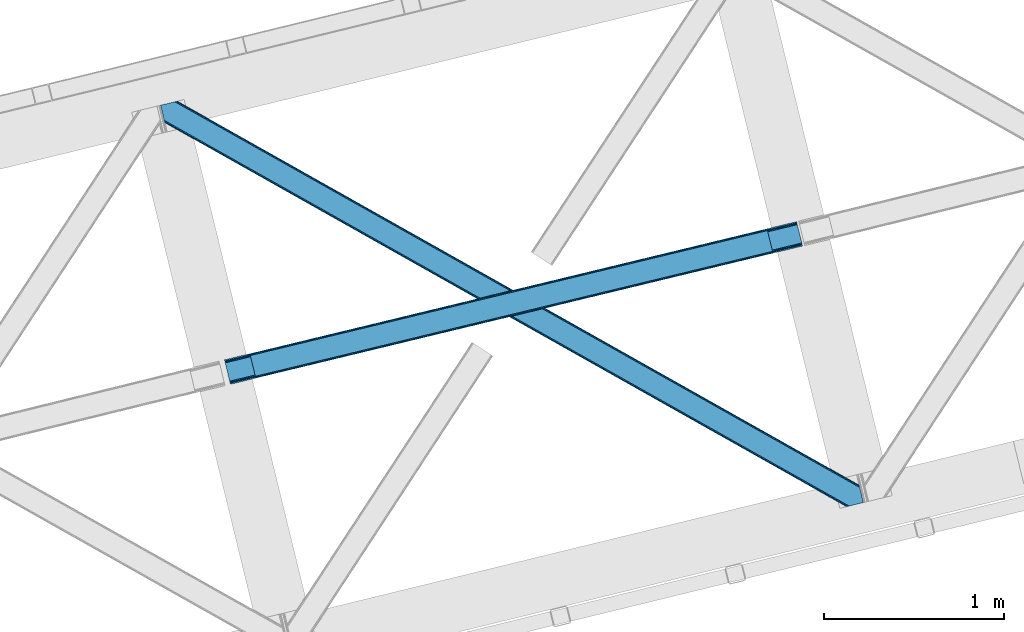
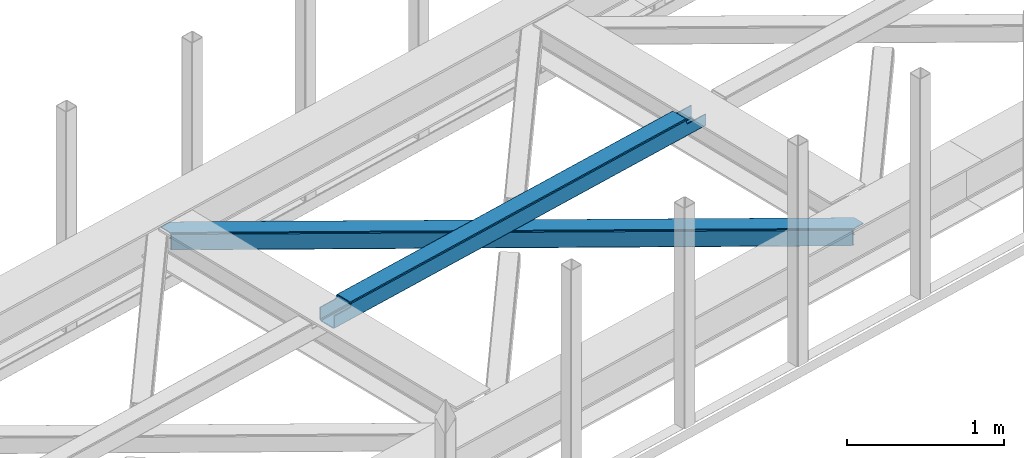
# One storey, part 28 of 66: 1 beam, 1 member.
"""IFC4 building model written with IfcOpenShell, lengths in millimetres."""

from ifc_helpers import new_model, entity, si_unit, converted_unit, derived_unit, direction, frame, origin, place, context, subcontext, project, spatial, triangles, type_object, element, save


model = new_model("IFC4")

# Units and contexts
model_context = context("Model", 3, precision=0.01, world=origin(), true_north=direction((6.12303176911189e-17, 1.0)))
plan_context = context("Plan", 3, precision=0.01, world=origin(), true_north=direction((6.12303176911189e-17, 1.0)))
body_context = subcontext(model_context, "Body", "Model", "MODEL_VIEW")
ifc_project = project(units=[si_unit("LENGTHUNIT", "METRE", prefix="MILLI"), si_unit("AREAUNIT", "SQUARE_METRE"), si_unit("VOLUMEUNIT", "CUBIC_METRE"), converted_unit("PLANEANGLEUNIT", "DEGREE", entity("IfcRatioMeasure", 0.0174532925199433), si_unit("PLANEANGLEUNIT", "RADIAN"), dimensions=[0, 0, 0, 0, 0, 0, 0]), si_unit("MASSUNIT", "GRAM", prefix="KILO"), derived_unit("MASSDENSITYUNIT", [(si_unit("MASSUNIT", "GRAM", prefix="KILO"), 1), (si_unit("LENGTHUNIT", "METRE"), -3)]), derived_unit("MOMENTOFINERTIAUNIT", [(si_unit("LENGTHUNIT", "METRE"), 4)]), si_unit("TIMEUNIT", "SECOND"), si_unit("FREQUENCYUNIT", "HERTZ"), si_unit("THERMODYNAMICTEMPERATUREUNIT", "DEGREE_CELSIUS"), derived_unit("THERMALTRANSMITTANCEUNIT", [(si_unit("MASSUNIT", "GRAM", prefix="KILO"), 1), (si_unit("THERMODYNAMICTEMPERATUREUNIT", "KELVIN"), -1), (si_unit("TIMEUNIT", "SECOND"), -3)]), derived_unit("VOLUMETRICFLOWRATEUNIT", [(si_unit("LENGTHUNIT", "METRE"), 3), (si_unit("TIMEUNIT", "SECOND"), -1)]), derived_unit("MASSFLOWRATEUNIT", [(si_unit("MASSUNIT", "GRAM", prefix="KILO"), 1), (si_unit("TIMEUNIT", "SECOND"), -1)]), derived_unit("ROTATIONALFREQUENCYUNIT", [(si_unit("TIMEUNIT", "SECOND"), -1)]), si_unit("ELECTRICCURRENTUNIT", "AMPERE"), si_unit("ELECTRICVOLTAGEUNIT", "VOLT"), si_unit("POWERUNIT", "WATT"), si_unit("FORCEUNIT", "NEWTON", prefix="KILO"), si_unit("ILLUMINANCEUNIT", "LUX"), si_unit("LUMINOUSFLUXUNIT", "LUMEN"), si_unit("LUMINOUSINTENSITYUNIT", "CANDELA"), derived_unit("USERDEFINED", [(si_unit("MASSUNIT", "GRAM", prefix="KILO"), -1), (si_unit("LENGTHUNIT", "METRE"), -2), (si_unit("TIMEUNIT", "SECOND"), 3), (si_unit("LUMINOUSFLUXUNIT", "LUMEN"), 1)]), derived_unit("LINEARVELOCITYUNIT", [(si_unit("LENGTHUNIT", "METRE"), 1), (si_unit("TIMEUNIT", "SECOND"), -1)]), si_unit("PRESSUREUNIT", "PASCAL"), derived_unit("USERDEFINED", [(si_unit("LENGTHUNIT", "METRE"), -2), (si_unit("MASSUNIT", "GRAM", prefix="KILO"), 1), (si_unit("TIMEUNIT", "SECOND"), -2)]), derived_unit("LINEARFORCEUNIT", [(si_unit("MASSUNIT", "GRAM", prefix="KILO"), 1), (si_unit("LENGTHUNIT", "METRE"), 1), (si_unit("TIMEUNIT", "SECOND"), -2), (si_unit("LENGTHUNIT", "METRE"), -1)]), derived_unit("PLANARFORCEUNIT", [(si_unit("MASSUNIT", "GRAM", prefix="KILO"), 1), (si_unit("LENGTHUNIT", "METRE"), 1), (si_unit("TIMEUNIT", "SECOND"), -2), (si_unit("LENGTHUNIT", "METRE"), -2)])], contexts=[model_context, plan_context])

# Site, building, storey
site_placement = place(None, origin())
site = spatial("IfcSite", under=ifc_project, at=site_placement, CompositionType="ELEMENT")
building_placement = place(site_placement, origin())
building = spatial("IfcBuilding", under=site, at=building_placement, CompositionType="ELEMENT")
storey_placement = place(building_placement, frame((0.0, 0.0, 19800.0)))
storey = spatial("IfcBuildingStorey", under=building, at=storey_placement, Name="06", CompositionType="ELEMENT", Elevation=19800.0)

# Beam
beam_type = type_object("IfcBeamType", PredefinedType="BEAM")
beam_placement = place(storey_placement, frame((-45771.85, 7982.52, 3967.03)))
element("IfcBeam", 1, at=beam_placement, inside=storey, type_object=beam_type, ObjectType="Steel Beam", PredefinedType="BEAM", context=body_context, shape_type="Tessellation", body=[
    triangles([(3181.73602294922, 886.704597473145, 0.969708251952397), (3206.60427246094, 784.691638183594, 0.969708251952397), (29.012182617189, 17.0018692016602, 0.0), (4.14393310547166, 119.015409851074, 0.0), (3180.15007324219, 893.211177062989, 2.30218505859375), (2.5579833984375, 125.521989440918, 1.33247680664135), (3178.80596923828, 898.727119445801, 6.09497680663844), (1.21387939453416, 131.037350463867, 5.12526855468604), (3177.90834960938, 902.412940979004, 11.7736999511726), (0.316259765626455, 134.72317199707, 10.8016662597656), (3177.59208984375, 903.707048034668, 18.4709655761726), (0.0, 136.017279052734, 17.4989318847656), (3210.43194580078, 768.983876037597, 11.7736999511726), (3210.74820556641, 767.689187622071, 18.4709655761726), (33.1561157226606, 0.0, 17.4989318847656), (32.8398559570342, 1.29410705566443, 10.8016662597656), (3209.53432617188, 772.669116210938, 6.09497680663844), (31.9422363281265, 4.97992858886755, 5.12526855468604), (3208.19022216797, 778.18505859375, 2.30218505859375), (30.5981323242231, 10.4952896118166, 1.33247680664135), (3179.5640625, 895.611611938477, 18.7732727050789), (3177.59208984375, 903.707048034668, 100.470611572266), (3179.24780273438, 896.906300354003, 25.4705383300789), (3179.24780273438, 896.906300354003, 100.470611572266), (3180.46168212891, 891.926371765137, 13.0945495605447), (3181.81043701172, 886.410429382324, 9.3017578125), (3183.39638671876, 879.903849792481, 7.96928100585865), (3207.87396240234, 779.470445251465, 13.0945495605447), (3208.77623291016, 775.784623718262, 18.7732727050789), (3209.08784179688, 774.490516662598, 25.4705383300789), (3210.74820556641, 767.689187622071, 100.470611572266), (3209.08784179688, 774.490516662598, 100.470611572266), (3206.52985839844, 784.986387634277, 9.3017578125), (3204.94390869141, 791.492385864258, 7.96928100585865), (27.3518188476592, 23.8026168823244, 6.99957275390625), (5.79964599609957, 112.214662170411, 6.99957275390625), (1.97197265625437, 127.922424316406, 17.8035644531228), (1.65571289062791, 129.216531372071, 24.4985046386719), (2.86959228516207, 124.236602783203, 12.1248413085923), (4.21369628906541, 118.72066040039, 8.3320495605476), (28.9377685546933, 17.2966186523436, 8.3320495605476), (30.2818725585967, 11.7806762695309, 12.1248413085923), (31.1794921875044, 8.09485473632776, 17.8035644531228), (31.4957519531308, 6.80074768066424, 24.4985046386719), (3015.94614257813, 857.452894592285, 100.470611572266), (3014.29042968751, 864.254223632812, 100.470611572266), (3047.44654541016, 728.236363220214, 100.470611572266), (3045.78618164063, 735.037110900879, 100.470611572266), (0.0, 136.017279052734, 104.491296386717), (1.65571289062791, 129.216531372071, 104.491296386717), (33.1561157226606, 0.0, 104.491296386717), (31.4957519531308, 6.80074768066424, 104.491296386717), (131.908227539068, 160.684959411621, 104.491296386717), (130.25251464844, 167.485707092285, 104.491296386717), (163.408630371094, 31.4684280395504, 104.491296386717), (161.748266601564, 38.2691757202147, 104.491296386717), (135.689392089844, 161.598275756836, 106.102825927734), (134.033679199223, 168.3990234375, 106.102825927734), (139.470556640626, 162.511592102051, 107.71435546875), (137.814843750006, 169.312339782715, 107.71435546875), (141.037902832031, 162.890057373047, 111.602490234374), (139.377539062501, 169.690805053711, 111.602490234374), (142.600598144534, 163.268522644043, 115.541784667967), (140.944885253906, 170.069270324707, 115.492950439453), (174.101000976567, 34.0514099121092, 115.492950439453), (172.440637207037, 40.8527389526371, 115.541784667967), (170.877941894534, 40.4742736816406, 111.602490234374), (172.533654785162, 33.6735260009764, 111.602490234374), (170.96630859375, 33.2950607299808, 107.71435546875), (169.310595703129, 40.0958084106442, 107.71435546875), (167.189794921876, 32.3817443847656, 106.102825927734), (165.529431152347, 39.1824920654299, 106.102825927734), (3013.3183959961, 864.019354248047, 101.47287597656), (3013.3183959961, 864.019354248047, 123.420373535155), (140.944885253906, 170.069270324707, 122.541357421873), (3046.47451171876, 728.001493835449, 123.420373535155), (174.101000976567, 34.0514099121092, 122.541357421873), (3014.97410888672, 857.218606567383, 116.420800781249), (3044.81414794922, 734.802241516114, 101.47287597656), (3044.81414794922, 734.802241516114, 116.420800781249), (3013.63465576172, 862.725247192382, 130.117639160155), (141.261145019533, 168.775163269043, 129.238623046873), (3014.53227539063, 859.039425659179, 135.794036865234), (142.15876464844, 165.08934173584, 134.917346191407), (3015.87637939453, 853.523483276367, 139.586828613279), (143.502868652344, 159.573399353028, 138.710137939452), (3017.46232910157, 847.016903686523, 140.91930541992), (145.088818359378, 153.066819763184, 140.042614746093), (3042.33057861328, 745.003944396973, 140.91930541992), (169.957067871095, 51.053860473633, 140.042614746093), (3043.91652832032, 738.497364807128, 139.586828613279), (171.543017578129, 44.5472808837894, 138.710137939452), (3045.26063232422, 732.981422424316, 135.794036865234), (172.887121582033, 39.0313385009767, 134.917346191407), (3046.15825195313, 729.295600891113, 130.117639160155), (173.78474121094, 35.3455169677736, 129.238623046873), (3016.18798828125, 852.238677978516, 128.794464111328), (3017.53209228516, 846.722735595704, 132.587255859373), (3019.11804199219, 840.216156005859, 133.919732666014), (3040.67021484375, 751.804692077636, 133.919732666014), (3015.29036865235, 855.923918151855, 123.115740966798), (3014.97410888672, 857.218606567383, 101.47287597656), (3042.25616455078, 745.298112487793, 132.587255859373), (3043.60026855469, 739.78217010498, 128.794464111328), (3044.5025390625, 736.09692993164, 123.115740966798), (3046.47451171876, 728.001493835449, 101.47287597656), (143.814477539068, 158.288594055176, 127.917773437501), (142.916857910161, 161.973834228515, 122.239050292967), (146.744531250006, 146.26607208252, 133.043041992187), (168.296704101565, 57.8546081542972, 133.043041992187), (145.158581542972, 152.772651672363, 131.710565185545), (171.226757812503, 45.832086181641, 127.917773437501), (172.129028320313, 42.1468460083006, 122.239050292967), (169.8826538086, 51.3480285644528, 131.710565185545)], [[1, 2, 3], [3, 4, 1], [5, 1, 4], [4, 6, 5], [7, 5, 6], [6, 8, 7], [9, 7, 8], [8, 10, 9], [11, 9, 10], [10, 12, 11], [13, 14, 15], [15, 16, 13], [17, 13, 16], [16, 18, 17], [19, 17, 18], [18, 20, 19], [2, 19, 20], [20, 3, 2], [9, 11, 21], [22, 23, 11], [23, 22, 24], [23, 21, 11], [25, 9, 21], [25, 7, 9], [5, 25, 26], [25, 5, 7], [26, 1, 5], [1, 27, 2], [27, 1, 26], [13, 28, 29], [29, 14, 13], [29, 30, 14], [30, 31, 14], [32, 31, 30], [33, 28, 19], [2, 33, 19], [34, 2, 27], [2, 34, 33], [19, 28, 17], [17, 28, 13], [34, 27, 35], [36, 35, 27], [21, 23, 37], [38, 37, 23], [25, 21, 39], [37, 39, 21], [26, 25, 40], [39, 40, 25], [27, 26, 36], [40, 36, 26], [33, 34, 41], [35, 41, 34], [28, 33, 42], [41, 42, 33], [29, 28, 43], [42, 43, 28], [30, 29, 44], [43, 44, 29], [24, 22, 45], [46, 45, 22], [31, 32, 47], [48, 47, 32], [39, 10, 8], [39, 8, 6], [39, 6, 40], [36, 4, 3], [4, 40, 6], [36, 40, 4], [10, 37, 12], [49, 38, 50], [49, 12, 38], [10, 39, 37], [37, 38, 12], [41, 20, 42], [3, 35, 36], [41, 3, 20], [3, 41, 35], [18, 16, 42], [42, 20, 18], [16, 43, 42], [44, 43, 15], [15, 43, 16], [44, 51, 52], [15, 51, 44], [53, 54, 50], [49, 50, 54], [55, 56, 51], [52, 51, 56], [57, 58, 53], [54, 53, 58], [59, 60, 57], [58, 57, 60], [61, 62, 59], [60, 59, 62], [63, 64, 61], [62, 61, 64], [65, 66, 67], [67, 68, 65], [68, 67, 69], [70, 69, 67], [69, 70, 71], [72, 71, 70], [71, 72, 55], [56, 55, 72], [73, 62, 64], [11, 12, 73], [73, 22, 11], [64, 74, 73], [75, 74, 64], [60, 73, 12], [12, 54, 58], [12, 49, 54], [58, 60, 12], [60, 62, 73], [47, 15, 14], [76, 65, 47], [77, 65, 76], [47, 65, 68], [47, 14, 31], [15, 47, 69], [68, 69, 47], [69, 71, 15], [55, 15, 71], [15, 55, 51], [45, 38, 23], [63, 45, 78], [45, 63, 61], [45, 61, 59], [45, 23, 24], [38, 45, 59], [59, 57, 38], [53, 38, 57], [38, 53, 50], [79, 70, 67], [30, 44, 79], [79, 32, 30], [79, 66, 80], [79, 67, 66], [70, 79, 44], [44, 56, 72], [44, 52, 56], [72, 70, 44], [81, 74, 82], [75, 82, 74], [83, 81, 84], [82, 84, 81], [85, 83, 86], [84, 86, 83], [87, 85, 88], [86, 88, 85], [89, 87, 90], [88, 90, 87], [91, 89, 92], [90, 92, 89], [93, 91, 94], [92, 94, 91], [95, 93, 96], [94, 96, 93], [76, 95, 77], [96, 77, 95], [97, 81, 83], [97, 83, 85], [97, 85, 98], [99, 87, 100], [87, 98, 85], [99, 98, 87], [81, 101, 74], [73, 78, 102], [73, 74, 78], [81, 97, 101], [101, 78, 74], [103, 91, 104], [89, 100, 87], [103, 89, 91], [89, 103, 100], [93, 95, 104], [104, 91, 93], [95, 105, 104], [80, 105, 76], [76, 105, 95], [80, 106, 79], [76, 106, 80], [107, 84, 82], [75, 108, 82], [75, 64, 63], [63, 108, 75], [108, 107, 82], [107, 86, 84], [109, 110, 88], [86, 111, 88], [111, 86, 107], [111, 109, 88], [96, 94, 112], [112, 113, 96], [113, 66, 77], [113, 77, 96], [66, 65, 77], [112, 92, 114], [90, 114, 92], [110, 90, 88], [90, 110, 114], [112, 94, 92], [98, 99, 109], [109, 111, 98], [97, 98, 111], [111, 107, 97], [101, 97, 107], [107, 108, 101], [78, 101, 108], [108, 63, 78], [99, 100, 110], [110, 109, 99], [105, 80, 66], [66, 113, 105], [104, 105, 113], [113, 112, 104], [103, 104, 112], [112, 114, 103], [100, 103, 114], [114, 110, 100]]),
])

# Member
member_type = type_object("IfcMemberType", PredefinedType="BRACE")
member_placement = place(storey_placement, frame((-46126.76, 7302.47, 3824.0)))
element("IfcMember", 2, at=member_placement, inside=storey, type_object=member_type, ObjectType="Steel Horizontal Brace", PredefinedType="BRACE", context=body_context, shape_type="Tessellation", body=[
    triangles([(3809.33957519531, 0.0, 122.499499511719), (3811.23713378907, 0.461599731444949, 129.196765136719), (23.4590332031221, 2133.54767761231, 129.196765136719), (23.8915649414048, 2131.77569274902, 122.499499511719), (3816.63215332032, 1.7772171020506, 134.87548828125), (22.231201171875, 2138.59446258545, 134.87548828125), (3824.70607910156, 3.74512023925763, 138.668280029298), (20.3894531249971, 2146.14690856934, 138.668280029298), (3834.23107910156, 6.06707153320258, 140.00075683594), (18.2174926757798, 2155.05566711426, 140.00075683594), (1916.9806640625, 1065.68146362305, 17.5012573242202), (2556.11839599609, 705.752851867675, 17.5012573242202), (3195.25147705078, 345.824240112304, 17.5012573242202), (3809.33957519531, 0.0, 17.5012573242202), (1277.84758300781, 1425.61065673828, 17.5012573242202), (638.714501953124, 1785.53868713379, 17.5012573242202), (23.8915649414048, 2131.77569274902, 17.5012573242202), (3885.46516113282, 97.721360778809, 140.00075683594), (3903.67800292969, 22.9956893920898, 140.00075683594), (69.4469238281235, 2246.70995635986, 140.00075683594), (0.0, 2229.78191986084, 140.00075683594), (3883.29320068359, 106.630700683594, 138.668280029298), (78.971923828125, 2249.03190765381, 138.668280029298), (3881.45145263672, 114.18314666748, 134.87548828125), (87.0458496093779, 2250.99981079102, 134.87548828125), (3880.21896972656, 119.229350280762, 129.196765136719), (92.4455200195298, 2252.31542816162, 129.196765136719), (3879.78643798828, 121.001335144043, 122.499499511719), (94.3384277343721, 2252.77702789307, 122.499499511719), (3265.41928710938, 466.982542419433, 17.5012573242202), (3879.78643798828, 121.001335144043, 17.5012573242202), (2626.2955078125, 826.905340576172, 17.5012573242202), (1987.17172851563, 1186.82813873291, 17.5012573242202), (708.924169921876, 1906.67315368652, 17.5012573242202), (94.3384277343721, 2252.77702789307, 17.5012573242202), (1348.04794921875, 1546.75093688965, 17.5012573242202), (82.4879882812529, 2249.88825073242, 122.197192382813), (69.01904296875, 2246.60531158447, 131.668707275392), (59.4940429687485, 2244.28336029053, 133.001184082033), (0.0, 2229.78191986084, 133.001184082033), (77.0929687500029, 2248.57321472168, 127.873590087893), (84.3808959960952, 2250.35043182373, 24.5008300781265), (77.0929687500029, 2248.57321472168, 12.1248413085959), (91.5851074218735, 2252.10613861084, 9.49942016601563), (82.4879882812529, 2249.88825073242, 17.8035644531265), (84.3808959960952, 2250.35043182373, 115.499926757813), (72.3118652343765, 2247.40816955566, 9.49942016601563), (92.0548461914077, 2252.22124786377, 10.8691040039084), (1983.48823242188, 1180.86745605469, 24.5008300781265), (3882.05606689453, 111.689694213867, 115.499926757813), (2626.78850097656, 818.593057250977, 24.5008300781265), (3270.08876953125, 456.319239807129, 24.5008300781265), (3882.05606689453, 111.689694213867, 24.5008300781265), (1340.19261474609, 1543.14127349854, 24.5008300781265), (696.892346191409, 1905.41509094238, 24.5008300781265), (3882.48859863282, 109.917709350586, 122.197192382813), (3883.72108154297, 104.870924377441, 127.873590087893), (3885.56282958984, 97.3184783935549, 131.668707275392), (3887.73479003906, 88.4097198486324, 133.001184082033), (3883.72108154297, 104.870924377441, 12.1248413085959), (3885.41865234375, 97.9004196166989, 8.52041015625218), (3880.59104003906, 117.703280639648, 8.52041015625218), (3903.67800292969, 22.9956893920898, 133.001184082033), (3882.48859863282, 109.917709350586, 17.8035644531265), (3880.37709960937, 118.591017150879, 10.9365417480476), (3844.18861083985, 8.4942489624018, 133.001184082033), (15.9478637695283, 2164.36730804443, 133.001184082033), (3834.66361083985, 6.17229766845685, 131.668707275392), (18.1198242187529, 2155.45854949951, 131.668707275392), (3826.58968505859, 4.20381317138617, 127.873590087893), (19.9615722656235, 2147.90610351562, 127.873590087893), (3821.19001464844, 2.88877716064417, 122.197192382813), (21.1894042968779, 2142.85989990234, 122.197192382813), (3819.29710693359, 2.42659606933557, 115.499926757813), (21.6219360351533, 2141.0873336792, 115.499926757813), (3208.50183105469, 346.39571685791, 24.5008300781265), (3819.29710693359, 2.42659606933557, 24.5008300781265), (2565.16435546875, 708.690463256836, 24.5008300781265), (1921.83153076172, 1070.98579101562, 24.5008300781265), (635.156579589842, 1795.57528381348, 24.5008300781265), (21.6219360351533, 2141.0873336792, 24.5008300781265), (1278.49405517578, 1433.28053741455, 24.5008300781265), (21.1894042968779, 2142.85989990234, 17.8035644531265), (23.263696289061, 2134.3505355835, 9.49942016601563), (19.9615722656235, 2147.90610351562, 12.1248413085959), (23.3706665039063, 2133.90986480713, 10.8691040039084), (18.8686157226548, 2152.37676086426, 9.49942016601563), (3826.58968505859, 4.20381317138617, 12.1248413085959), (3812.86959228515, 0.859831237792605, 8.52041015625218), (3821.19001464844, 2.88877716064417, 17.8035644531265), (3834.0403930664, 6.02056274414008, 8.52041015625218), (3811.91616210937, 0.628450012206486, 10.9365417480476), (190.667431640628, 2055.62743377686, 9.49942016601563), (195.062512207034, 2037.60120849609, 9.49942016601563), (196.076403808591, 2037.6692276001, 8.49948120117188), (196.057800292969, 2037.42389373779, 8.8831787109375), (191.295300292972, 2056.67155609131, 8.85294799804615), (195.732238769531, 2037.48144836426, 9.08316650390771), (191.351110839845, 2055.8262588501, 9.20641479492406), (195.388073730472, 2037.54365386963, 9.29943237304906), (191.011596679688, 2055.72684631348, 9.35291748046802), (191.239489746091, 2057.51627197266, 8.49948120117188), (150.921020507813, 2218.6901550293, 9.49942016601563), (155.316101074219, 2200.6645111084, 9.49942016601563), (151.251232910159, 2218.34947814941, 9.25757446289208), (155.813745117186, 2200.23721160889, 9.42500610351635), (151.609350585939, 2217.98496551514, 8.99945068359375), (156.250927734378, 2199.30471038818, 9.11804809570458), (151.96281738281, 2217.619871521, 8.74132690429906), (156.692761230472, 2198.3640701294, 8.80643920898365), (152.297680664065, 2217.27919464111, 8.49948120117188), (157.134594726565, 2197.43156890869, 8.49948120117188), (3713.61983642578, 194.649165344238, 8.52041015625218), (3708.79222412109, 214.452026367188, 8.52041015625218), (3713.26636962891, 194.529405212403, 8.40181274414135), (3708.39689941406, 214.570623779297, 8.37390747070458), (3713.06638183594, 194.460223388672, 8.3320495605476), (3708.00622558594, 214.689221191406, 8.22740478515698), (3707.9085571289, 214.477606201172, 7.87393798828271), (3713.1175415039, 193.949789428711, 8.19484863281468), (3707.80623779297, 214.265991210938, 7.52047119140843), (3713.23846435547, 192.705679321289, 7.85765991211156), (3713.36403808594, 191.464476013183, 7.52047119140843), (3264.76351318359, 465.821566772461, 10.8039916992202), (3262.90316162109, 462.516535949707, 5.12526855468968), (3260.11728515625, 457.569163513183, 1.33247680664135), (3708.58293457031, 211.087696838379, 5.59500732422021), (708.268395996092, 1905.51275939941, 10.8039916992202), (706.408044433592, 1902.2071472168, 5.12526855468968), (153.148791503903, 2213.77533874512, 5.12526855468968), (703.622167968751, 1897.26035614014, 1.33247680664135), (154.990539550781, 2206.22289276123, 1.33247680664135), (700.333996582034, 1891.42524719238, 0.0), (157.162499999999, 2197.31355285645, 0.0), (3710.29910888672, 204.051498413086, 1.33247680664135), (3712.47106933594, 195.142739868164, 0.0), (3256.83376464844, 451.73405456543, 0.0), (2625.63973388672, 825.744364929199, 10.8039916992202), (1986.51595458984, 1185.66716308594, 10.8039916992202), (1347.39217529297, 1545.58996124268, 10.8039916992202), (2623.77938232422, 822.439334106445, 5.12526855468968), (1984.65560302734, 1182.36213226318, 5.12526855468968), (1345.53182373047, 1542.28434906006, 5.12526855468968), (2620.99350585938, 817.491961669922, 1.33247680664135), (1981.8697265625, 1177.41475982666, 1.33247680664135), (1342.74594726563, 1537.3375579834, 1.33247680664135), (2617.70998535156, 811.656852722168, 0.0), (1978.58620605469, 1171.57965087891, 0.0), (1339.46242675781, 1531.50244903564, 0.0), (3746.51550292969, 55.4634750366213, 0.0), (3203.83699951172, 361.072146606445, 0.0), (2564.70391845703, 721.00133972168, 0.0), (1925.57083740235, 1080.92995147705, 0.0), (1286.43310546875, 1440.85856323242, 0.0), (647.300024414064, 1800.78717498779, 0.0), (191.211584472658, 2057.6342880249, 0.0), (3195.90725097656, 346.984634399414, 10.8039916992202), (639.365624999999, 1786.69966278076, 10.8039916992202), (641.230627441408, 1790.00527496338, 5.12526855468968), (195.225292968753, 2041.17308349609, 5.12526855468968), (3197.76760253906, 350.290246582032, 5.12526855468968), (3200.55347900391, 355.237037658691, 1.33247680664135), (3748.6874633789, 46.5547164916989, 1.33247680664135), (3752.58024902343, 34.8100845336912, 8.52041015625218), (3750.40363769532, 39.517936706543, 5.59500732422021), (3751.18033447266, 36.3402236938473, 7.52047119140843), (3752.24073486328, 35.1809921264648, 8.278564453125), (644.011853027347, 1794.95206604004, 1.33247680664135), (193.383544921875, 2048.72611083984, 1.33247680664135), (2561.42039794922, 715.165649414063, 1.33247680664135), (1922.28266601563, 1075.0948425293, 1.33247680664135), (1283.14958496093, 1435.02345428467, 1.33247680664135), (2558.63452148438, 710.218858337403, 5.12526855468968), (1919.49678955078, 1070.14747009277, 5.12526855468968), (1280.36370849609, 1430.07666320801, 5.12526855468968), (2556.76951904297, 706.913246154785, 10.8039916992202), (1917.63643798828, 1066.84243927002, 10.8039916992202), (1278.50335693359, 1426.77105102539, 10.8039916992202), (3745.62253417969, 59.1411575317379, 7.52047119140843), (3746.13878173828, 57.3430114746097, 7.90416870117406), (3746.6736328125, 56.436090087891, 8.10880737304615), (3747.30150146484, 55.3762710571291, 8.34832763671875), (3747.75263671875, 54.6129455566406, 8.52041015625218), (3211.01795654297, 350.861723327636, 12.1248413085959), (3217.09200439453, 361.644204711914, 6.99957275390625), (3213.80383300781, 355.808514404297, 8.3320495605476), (3744.24587402344, 64.7751159667969, 6.99957275390625), (643.742102050783, 1810.82377166748, 6.99957275390625), (188.941955566406, 2066.94651031494, 6.99957275390625), (637.672705078126, 1800.0412902832, 12.1248413085959), (640.458581542967, 1804.98866271973, 8.3320495605476), (635.812353515626, 1796.73625946045, 17.8035644531265), (3209.15760498047, 347.55611114502, 17.8035644531265), (2565.82012939453, 709.851438903808, 17.8035644531265), (1922.48265380859, 1072.14618530273, 17.8035644531265), (1279.14982910156, 1434.44151306152, 17.8035644531265), (2567.68048095703, 713.156469726562, 12.1248413085959), (1924.34765625, 1075.45179748535, 12.1248413085959), (1281.01018066406, 1437.74654388428, 12.1248413085959), (2570.46635742187, 718.103842163086, 8.3320495605476), (1927.12888183594, 1080.39858856201, 8.3320495605476), (1283.79605712891, 1442.69333496094, 8.3320495605476), (2573.7545288086, 723.93895111084, 6.99957275390625), (1930.41705322266, 1086.23369750977, 6.99957275390625), (1287.07957763672, 1448.52902526856, 6.99957275390625), (694.376220703125, 1900.94908447266, 12.1248413085959), (691.590344238284, 1896.00287475586, 8.3320495605476), (157.264819335935, 2196.88450927734, 8.41343994140698), (159.43212890625, 2188.00191192627, 6.99957275390625), (3261.50324707032, 441.070751953125, 6.99957275390625), (3264.79141845703, 446.905860900879, 8.3320495605476), (3714.74069824219, 185.830517578125, 6.99957275390625), (3267.57264404297, 451.852651977539, 12.1248413085959), (688.30217285156, 1890.16718444824, 6.99957275390625), (696.236572265625, 1904.25469665527, 17.8035644531265), (3269.43764648437, 455.158264160156, 17.8035644531265), (2621.49114990234, 809.18025970459, 8.3320495605476), (2618.20297851563, 803.344569396972, 6.99957275390625), (1978.19088134765, 1171.45407714844, 8.3320495605476), (1974.90270996094, 1165.61896820068, 6.99957275390625), (1331.60244140625, 1527.89278564453, 6.99957275390625), (1334.89061279297, 1533.72847595215, 8.3320495605476), (2624.27702636718, 814.12705078125, 12.1248413085959), (1980.9767578125, 1176.4008682251, 12.1248413085959), (1337.67648925781, 1538.67526702881, 12.1248413085959), (2626.13737792968, 817.432662963867, 17.8035644531265), (1982.837109375, 1179.70648040771, 17.8035644531265), (1339.53684082031, 1541.98087921143, 17.8035644531265)], [[1, 2, 3], [3, 4, 1], [2, 5, 6], [6, 3, 2], [5, 7, 8], [8, 6, 5], [7, 9, 10], [10, 8, 7], [11, 1, 4], [1, 12, 13], [11, 12, 1], [13, 14, 1], [15, 4, 16], [4, 15, 11], [17, 16, 4], [9, 18, 10], [9, 19, 18], [20, 10, 18], [21, 10, 20], [18, 22, 23], [23, 20, 18], [22, 24, 25], [25, 23, 22], [24, 26, 27], [27, 25, 24], [26, 28, 29], [29, 27, 26], [30, 28, 31], [28, 30, 32], [28, 33, 29], [33, 28, 32], [34, 35, 29], [36, 29, 33], [29, 36, 34], [37, 29, 27], [38, 23, 20], [21, 39, 20], [39, 21, 40], [39, 38, 20], [41, 23, 38], [41, 37, 25], [25, 23, 41], [27, 25, 37], [42, 35, 29], [43, 44, 45], [37, 46, 29], [43, 47, 44], [42, 45, 35], [46, 42, 29], [48, 35, 45], [45, 44, 48], [49, 50, 46], [50, 51, 52], [49, 51, 50], [52, 53, 50], [54, 46, 55], [46, 54, 49], [42, 55, 46], [50, 56, 46], [37, 46, 56], [56, 57, 37], [41, 37, 57], [57, 58, 41], [38, 41, 58], [58, 59, 38], [39, 38, 59], [57, 24, 22], [60, 61, 62], [24, 57, 56], [58, 57, 22], [58, 18, 59], [19, 59, 18], [59, 19, 63], [58, 22, 18], [31, 28, 53], [62, 64, 60], [64, 31, 53], [65, 64, 62], [65, 31, 64], [28, 50, 53], [56, 26, 24], [28, 26, 56], [50, 28, 56], [59, 66, 67], [66, 59, 63], [67, 39, 59], [40, 39, 67], [66, 68, 67], [69, 67, 68], [68, 70, 69], [71, 69, 70], [70, 72, 71], [73, 71, 72], [72, 74, 73], [75, 73, 74], [76, 74, 77], [74, 76, 78], [74, 79, 75], [79, 74, 78], [80, 81, 75], [82, 75, 79], [75, 82, 80], [83, 84, 85], [81, 4, 17], [17, 86, 83], [86, 84, 83], [83, 81, 17], [75, 4, 81], [73, 71, 6], [3, 73, 6], [3, 4, 73], [75, 73, 4], [71, 8, 6], [69, 8, 71], [87, 85, 84], [69, 67, 10], [69, 10, 8], [67, 21, 10], [67, 40, 21], [72, 1, 2], [68, 7, 9], [19, 66, 9], [66, 19, 63], [66, 68, 9], [70, 7, 68], [70, 72, 5], [5, 7, 70], [2, 5, 72], [77, 14, 1], [88, 89, 90], [72, 74, 1], [88, 91, 89], [77, 90, 14], [74, 77, 1], [92, 14, 90], [90, 89, 92], [93, 94, 84], [84, 87, 93], [95, 96, 97], [96, 98, 99], [99, 98, 100], [101, 100, 94], [94, 93, 101], [100, 101, 99], [99, 97, 96], [97, 102, 95], [103, 104, 44], [47, 44, 104], [105, 106, 104], [107, 108, 106], [109, 110, 108], [111, 112, 110], [110, 109, 111], [108, 107, 109], [106, 105, 107], [104, 103, 105], [62, 61, 113], [113, 114, 62], [115, 116, 114], [117, 118, 116], [116, 115, 117], [119, 118, 120], [121, 119, 122], [122, 123, 121], [120, 122, 119], [117, 120, 118], [114, 113, 115], [124, 30, 31], [125, 124, 118], [118, 119, 125], [119, 121, 125], [124, 65, 114], [114, 116, 124], [116, 118, 124], [65, 62, 114], [126, 125, 127], [48, 128, 103], [128, 129, 130], [130, 111, 128], [128, 109, 107], [109, 128, 111], [128, 105, 103], [105, 128, 107], [128, 48, 35], [35, 34, 128], [103, 44, 48], [129, 131, 132], [132, 130, 129], [131, 133, 134], [134, 132, 131], [135, 136, 137], [137, 126, 135], [127, 135, 126], [121, 127, 125], [31, 65, 124], [30, 124, 138], [138, 32, 30], [32, 138, 139], [139, 33, 32], [33, 139, 36], [140, 36, 139], [36, 140, 34], [128, 34, 140], [124, 125, 138], [141, 138, 125], [138, 141, 142], [142, 139, 138], [139, 142, 143], [143, 140, 139], [140, 143, 129], [129, 128, 140], [125, 126, 141], [144, 141, 126], [141, 144, 142], [145, 142, 144], [142, 145, 143], [146, 143, 145], [143, 146, 129], [131, 129, 146], [126, 137, 144], [147, 144, 137], [144, 147, 145], [148, 145, 147], [145, 148, 146], [149, 146, 148], [146, 149, 131], [133, 131, 149], [136, 150, 151], [137, 151, 147], [151, 137, 136], [148, 152, 153], [152, 147, 151], [148, 147, 152], [133, 149, 154], [153, 149, 148], [149, 153, 154], [155, 133, 154], [156, 133, 155], [134, 133, 156], [157, 92, 14], [158, 16, 17], [159, 96, 95], [158, 86, 94], [94, 159, 158], [94, 98, 159], [86, 84, 94], [95, 160, 159], [161, 162, 163], [92, 157, 164], [157, 161, 165], [165, 166, 157], [167, 164, 157], [157, 166, 167], [164, 89, 92], [163, 165, 161], [150, 163, 162], [162, 151, 150], [155, 168, 169], [169, 156, 155], [168, 159, 160], [160, 169, 168], [17, 86, 158], [14, 13, 157], [151, 162, 170], [170, 152, 151], [152, 170, 171], [171, 153, 152], [153, 171, 154], [172, 154, 171], [154, 172, 155], [168, 155, 172], [162, 161, 170], [173, 170, 161], [170, 173, 171], [174, 171, 173], [171, 174, 175], [175, 172, 171], [172, 175, 159], [159, 168, 172], [161, 157, 173], [176, 173, 157], [173, 176, 174], [177, 174, 176], [174, 177, 178], [178, 175, 174], [175, 178, 159], [158, 159, 178], [157, 13, 12], [12, 176, 157], [176, 12, 11], [11, 177, 176], [177, 11, 178], [15, 178, 11], [178, 15, 158], [16, 158, 15], [166, 179, 180], [166, 180, 181], [167, 181, 182], [167, 182, 183], [91, 89, 183], [164, 183, 89], [184, 183, 182], [88, 91, 183], [183, 184, 88], [185, 180, 179], [182, 185, 186], [182, 181, 185], [180, 185, 181], [179, 187, 185], [188, 189, 102], [93, 85, 190], [93, 87, 85], [102, 190, 191], [190, 102, 97], [97, 99, 190], [80, 192, 81], [83, 81, 192], [192, 190, 83], [85, 83, 190], [102, 191, 188], [182, 186, 184], [90, 88, 184], [184, 193, 90], [77, 90, 193], [193, 76, 77], [76, 193, 78], [194, 78, 193], [78, 194, 195], [195, 79, 78], [79, 195, 196], [196, 82, 79], [82, 196, 192], [192, 80, 82], [193, 184, 197], [197, 194, 193], [194, 197, 195], [198, 195, 197], [195, 198, 199], [199, 196, 195], [196, 199, 190], [190, 192, 196], [184, 186, 200], [200, 197, 184], [197, 200, 201], [201, 198, 197], [198, 201, 199], [202, 199, 201], [199, 202, 190], [191, 190, 202], [186, 185, 200], [203, 200, 185], [200, 203, 201], [204, 201, 203], [201, 204, 202], [205, 202, 204], [202, 205, 191], [188, 191, 205], [206, 106, 108], [108, 207, 206], [108, 110, 207], [110, 208, 207], [104, 206, 43], [43, 47, 104], [207, 208, 209], [210, 123, 122], [122, 211, 210], [122, 117, 211], [210, 212, 123], [213, 211, 117], [61, 60, 113], [213, 113, 60], [209, 214, 207], [206, 215, 45], [45, 43, 206], [215, 55, 42], [42, 45, 215], [64, 53, 216], [52, 216, 53], [60, 64, 213], [216, 213, 64], [210, 211, 217], [217, 218, 210], [218, 217, 219], [219, 220, 218], [220, 219, 221], [222, 221, 219], [221, 222, 207], [207, 214, 221], [211, 213, 217], [223, 217, 213], [217, 223, 219], [224, 219, 223], [219, 224, 222], [225, 222, 224], [222, 225, 207], [206, 207, 225], [213, 216, 226], [226, 223, 213], [223, 226, 227], [227, 224, 223], [224, 227, 228], [228, 225, 224], [225, 228, 215], [215, 206, 225], [216, 52, 51], [51, 226, 216], [226, 51, 227], [49, 227, 51], [227, 49, 228], [54, 228, 49], [228, 54, 215], [55, 215, 54], [209, 134, 189], [132, 208, 130], [208, 132, 134], [130, 208, 111], [134, 209, 208], [189, 134, 156], [169, 102, 156], [102, 169, 160], [156, 102, 189], [160, 95, 102], [136, 212, 187], [123, 127, 121], [136, 123, 212], [123, 135, 127], [123, 136, 135], [150, 136, 187], [179, 150, 187], [165, 179, 166], [179, 163, 150], [179, 165, 163], [203, 185, 210], [210, 218, 203], [218, 204, 203], [204, 218, 220], [185, 212, 210], [185, 187, 212], [214, 188, 221], [188, 214, 189], [209, 189, 214], [205, 221, 188], [220, 205, 204], [221, 205, 220]]),
])

save(model, "model.ifc")
